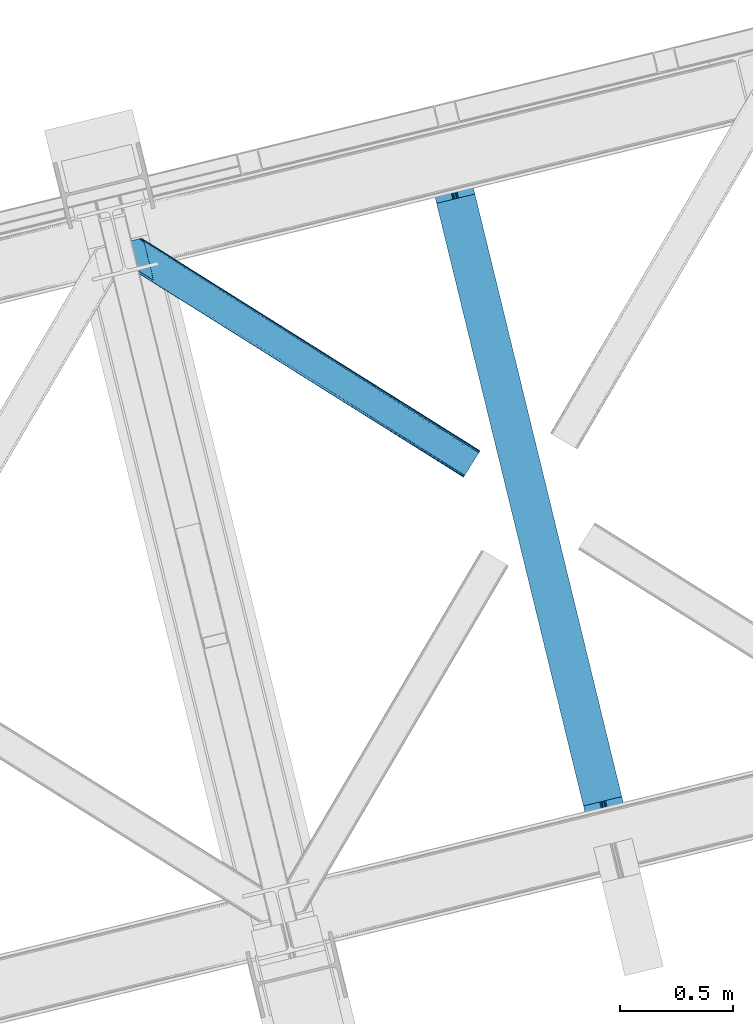
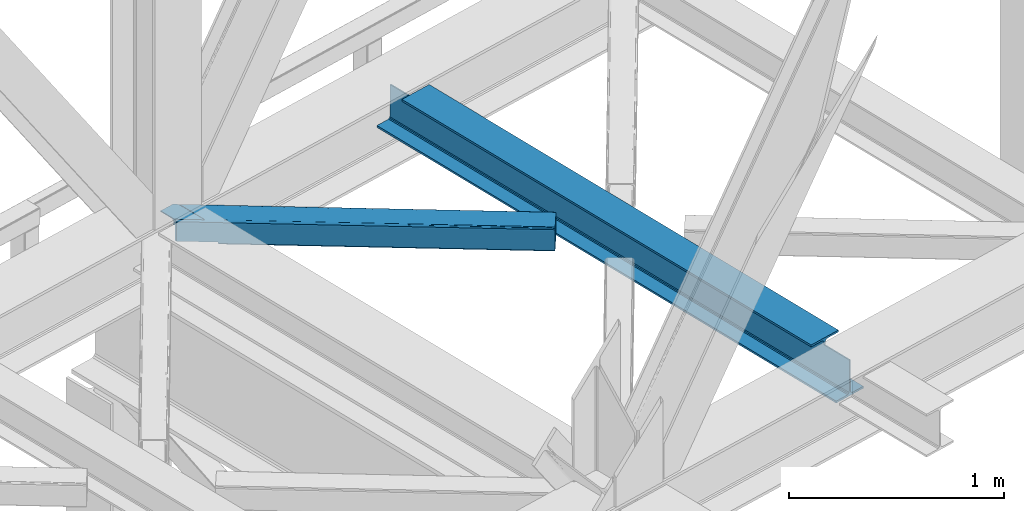
# One storey, part 32 of 92: 1 beam, 1 member.
"""IFC4 building model written with IfcOpenShell, lengths in millimetres."""

from ifc_helpers import new_model, entity, si_unit, converted_unit, derived_unit, direction, frame, origin, place, context, subcontext, project, spatial, triangles, polygons, material, type_object, element, save


model = new_model("IFC4")

# Units and contexts
model_context = context("Model", 3, precision=0.01, world=origin(), true_north=direction((6.12303176911189e-17, 1.0)))
plan_context = context("Plan", 3, precision=0.01, world=origin(), true_north=direction((6.12303176911189e-17, 1.0)))
body_context = subcontext(model_context, "Body", "Model", "MODEL_VIEW")
ifc_project = project(units=[si_unit("LENGTHUNIT", "METRE", prefix="MILLI"), si_unit("AREAUNIT", "SQUARE_METRE"), si_unit("VOLUMEUNIT", "CUBIC_METRE"), converted_unit("PLANEANGLEUNIT", "DEGREE", entity("IfcRatioMeasure", 0.0174532925199433), si_unit("PLANEANGLEUNIT", "RADIAN"), dimensions=[0, 0, 0, 0, 0, 0, 0]), si_unit("MASSUNIT", "GRAM", prefix="KILO"), derived_unit("MASSDENSITYUNIT", [(si_unit("MASSUNIT", "GRAM", prefix="KILO"), 1), (si_unit("LENGTHUNIT", "METRE"), -3)]), derived_unit("MOMENTOFINERTIAUNIT", [(si_unit("LENGTHUNIT", "METRE"), 4)]), si_unit("TIMEUNIT", "SECOND"), si_unit("FREQUENCYUNIT", "HERTZ"), si_unit("THERMODYNAMICTEMPERATUREUNIT", "DEGREE_CELSIUS"), derived_unit("THERMALTRANSMITTANCEUNIT", [(si_unit("MASSUNIT", "GRAM", prefix="KILO"), 1), (si_unit("THERMODYNAMICTEMPERATUREUNIT", "KELVIN"), -1), (si_unit("TIMEUNIT", "SECOND"), -3)]), derived_unit("VOLUMETRICFLOWRATEUNIT", [(si_unit("LENGTHUNIT", "METRE"), 3), (si_unit("TIMEUNIT", "SECOND"), -1)]), derived_unit("MASSFLOWRATEUNIT", [(si_unit("MASSUNIT", "GRAM", prefix="KILO"), 1), (si_unit("TIMEUNIT", "SECOND"), -1)]), derived_unit("ROTATIONALFREQUENCYUNIT", [(si_unit("TIMEUNIT", "SECOND"), -1)]), si_unit("ELECTRICCURRENTUNIT", "AMPERE"), si_unit("ELECTRICVOLTAGEUNIT", "VOLT"), si_unit("POWERUNIT", "WATT"), si_unit("FORCEUNIT", "NEWTON", prefix="KILO"), si_unit("ILLUMINANCEUNIT", "LUX"), si_unit("LUMINOUSFLUXUNIT", "LUMEN"), si_unit("LUMINOUSINTENSITYUNIT", "CANDELA"), derived_unit("USERDEFINED", [(si_unit("MASSUNIT", "GRAM", prefix="KILO"), -1), (si_unit("LENGTHUNIT", "METRE"), -2), (si_unit("TIMEUNIT", "SECOND"), 3), (si_unit("LUMINOUSFLUXUNIT", "LUMEN"), 1)]), derived_unit("LINEARVELOCITYUNIT", [(si_unit("LENGTHUNIT", "METRE"), 1), (si_unit("TIMEUNIT", "SECOND"), -1)]), si_unit("PRESSUREUNIT", "PASCAL"), derived_unit("USERDEFINED", [(si_unit("LENGTHUNIT", "METRE"), -2), (si_unit("MASSUNIT", "GRAM", prefix="KILO"), 1), (si_unit("TIMEUNIT", "SECOND"), -2)]), derived_unit("LINEARFORCEUNIT", [(si_unit("MASSUNIT", "GRAM", prefix="KILO"), 1), (si_unit("LENGTHUNIT", "METRE"), 1), (si_unit("TIMEUNIT", "SECOND"), -2), (si_unit("LENGTHUNIT", "METRE"), -1)]), derived_unit("PLANARFORCEUNIT", [(si_unit("MASSUNIT", "GRAM", prefix="KILO"), 1), (si_unit("LENGTHUNIT", "METRE"), 1), (si_unit("TIMEUNIT", "SECOND"), -2), (si_unit("LENGTHUNIT", "METRE"), -2)])], contexts=[model_context, plan_context])

# Site, building, storey
site_placement = place(None, origin())
site = spatial("IfcSite", under=ifc_project, at=site_placement, CompositionType="ELEMENT")
building_placement = place(site_placement, origin())
building = spatial("IfcBuilding", under=site, at=building_placement, CompositionType="ELEMENT")
storey_placement = place(building_placement, frame((0.0, 0.0, 15900.0)))
storey = spatial("IfcBuildingStorey", under=building, at=storey_placement, Name="05", CompositionType="ELEMENT", Elevation=15900.0)

# Beam
ifc_material = material(Name="Metal painted (White)")
beam_type = type_object("IfcBeamType", PredefinedType="BEAM")
beam_placement = place(storey_placement, frame((-53806.58, 4670.78, 3441.0)))
element("IfcBeam", 1, at=beam_placement, inside=storey, type_object=beam_type, material=ifc_material, ObjectType="Steel Beam", PredefinedType="BEAM", context=body_context, shape_type="Tessellation", body=[
    polygons([(900.985346189432, 41.4445662733081, 11.000000000004), (900.985346189432, 41.4445662733081, 2.16573425859679e-12), (170.021610174752, 3040.13999372697, 2.16573425859679e-12), (170.021610174752, 3040.13999372697, 11.000000000004), (834.919806235814, 25.3403919499656, 11.000000000004), (103.956070221144, 3024.03581940362, 11.000000000004), (828.971056214531, 23.8903211957396, 12.2179274798217), (98.0073201998513, 3022.5857486494, 12.2179274798217), (823.927949458422, 22.66101056892, 15.6862915010192), (92.9642134437427, 3021.35643802258, 15.6862915010192), (820.558253255246, 21.8396114687119, 20.8770650821657), (89.5945172405668, 3020.53503892237, 20.8770650821657), (819.374973305552, 21.5511744621206, 27.0000000000047), (88.4112372908809, 3020.24660191578, 27.0000000000047), (81.6103728838888, 3018.58881926485, 27.0000000000047), (81.6103728838888, 3018.58881926485, 203.000000000006), (88.4112372908723, 3020.24660191578, 203.000000000006), (-8.66293703438714e-12, 2998.69542745366, 2.16573425859679e-12), (8.66293703438714e-12, 2998.69542745366, 10.9999999999997), (66.0655399536259, 3014.799601777, 11.000000000004), (72.0142899749184, 3016.24967253123, 12.2179274798217), (77.0573967310357, 3017.47898315805, 15.6862915010192), (80.4270929342029, 3018.30038225826, 20.8770650821657), (819.374973305552, 21.5511744621206, 203.000000000006), (812.574108898559, 19.8933918111881, 203.000000000006), (812.574108898559, 19.8933918111881, 27.0000000000047), (811.390828948873, 19.6049548045968, 20.8770650821657), (808.021132745698, 18.7835557043887, 15.6862915010192), (802.978025989598, 17.5542450775691, 12.2179274798217), (797.029275968305, 16.1041743233431, 11.000000000004), (730.963736014671, 0.0, 10.9999999999997), (730.963736014671, 0.0, 2.16573425859679e-12), (779.675212882749, 184.415062601692, 203.069791966819), (128.020401343504, 2857.75452019162, 203.000000000006), (128.243282132658, 2856.8401777572, 203.617301946336), (128.256196377177, 2856.7871977843, 217.000003693143), (779.530009633833, 185.010597404072, 217.000003676718), (779.530880241722, 185.007025963192, 204.00000679514), (772.96491171832, 182.385463974442, 203.006342981529), (772.742064056782, 183.299815969774, 203.617301946336), (772.729149812254, 183.352795942667, 217.000003693143), (121.455336555608, 2855.1293963229, 217.000003676718), (121.454465947718, 2855.13296776377, 204.00000679514), (121.310166358664, 2855.72494066435, 203.076120467494), (121.219536936511, 2856.09673754069, 203.000000000006), (780.71349435786, 185.298194377514, 223.122939328039), (784.082490766547, 186.122464201395, 228.313710402595), (789.125126170563, 187.353708426699, 231.782072735464), (795.073705041266, 188.804481281381, 232.999999602236), (861.139155906781, 204.909021065315, 232.999999283132), (861.137682570352, 204.915065042188, 243.999994005812), (691.11630166644, 163.469558245298, 243.999994827032), (691.117775002877, 163.463514268424, 233.000000104353), (757.183225868401, 179.568054052359, 232.999999785253), (763.132130996722, 181.017488520583, 231.782072861016), (768.175695503862, 182.244921343718, 228.313710479427), (771.546082413593, 183.063487001147, 223.12293937232), (120.271851831572, 2854.84179934945, 223.122939328039), (116.902855422901, 2854.01752952557, 228.313710402595), (111.860220018877, 2852.78628530027, 231.782072735464), (105.911641148174, 2851.33551244559, 232.999999602236), (39.8461902826505, 2835.23097266165, 232.999999283128), (39.8476636190881, 2835.22492868478, 243.999994005812), (209.869044523001, 2876.67043548167, 243.999994827032), (209.867571186563, 2876.67647945854, 233.000000104357), (143.80212032104, 2860.57193967461, 232.999999785253), (137.853215192718, 2859.12250520639, 231.782072861012), (132.809650685587, 2857.89507238325, 228.313710479427), (129.439263775847, 2857.07650672582, 223.12293937232)], [[[1, 2, 3, 4]], [[5, 1, 4, 6]], [[7, 5, 6, 8]], [[9, 7, 8, 10]], [[11, 9, 10, 12]], [[13, 11, 12, 14]], [[15, 16, 17, 14, 12, 10, 8, 6, 4, 3, 18, 19, 20, 21, 22, 23]], [[13, 24, 25, 26, 27, 28, 29, 30, 31, 32, 2, 1, 5, 7, 9, 11]], [[2, 32, 18, 3]], [[32, 31, 19, 18]], [[31, 30, 20, 19]], [[27, 26, 15, 23]], [[28, 27, 23, 22]], [[29, 28, 22, 21]], [[30, 29, 21, 20]], [[33, 24, 13, 14, 17, 34, 35, 36, 37, 38]], [[25, 39, 40, 41, 42, 43, 44, 16, 15, 26]], [[39, 25, 24, 33]], [[45, 34, 17, 16]], [[41, 40, 38, 37, 46, 47, 48, 49, 50, 51, 52, 53, 54, 55, 56, 57]], [[42, 58, 59, 60, 61, 62, 63, 64, 65, 66, 67, 68, 69, 36, 35, 43]], [[46, 37, 36, 69]], [[47, 46, 69, 68]], [[48, 47, 68, 67]], [[49, 48, 67, 66]], [[50, 49, 66, 65]], [[51, 50, 65, 64]], [[52, 51, 64, 63]], [[53, 52, 63, 62]], [[54, 53, 62, 61]], [[55, 54, 61, 60]], [[56, 55, 60, 59]], [[57, 56, 59, 58]], [[41, 57, 58, 42]]], closed=False),
])

# Member
member_type = type_object("IfcMemberType", PredefinedType="BRACE")
member_placement = place(storey_placement, frame((-55162.19, 6291.05, 3511.0)))
element("IfcMember", 2, at=member_placement, inside=storey, type_object=member_type, ObjectType="Steel Horizontal Brace", PredefinedType="BRACE", context=body_context, shape_type="Tessellation", body=[
    triangles([(207.722204589845, 841.064360046386, 0.0), (172.045312499999, 987.426937866211, 0.0), (1579.92216796875, 103.755294799805, 0.0), (1524.10231933594, 14.8217697143555, 0.0), (1589.22392578125, 118.577645874023, 17.5000946044929), (1588.5169921875, 117.449226379395, 10.8028289794929), (166.547973632813, 1009.96393432617, 10.8028289794929), (166.096838378908, 1011.82079772949, 17.5000946044929), (1586.49851074219, 114.236050415039, 5.12526855468968), (167.840917968751, 1004.67646636963, 5.12526855468968), (1583.48474121094, 109.42762298584, 1.33247680664135), (169.766381835936, 996.762414550781, 1.33247680664135), (1520.53974609375, 9.15002288818323, 1.33247680664135), (202.587634277341, 836.378599548339, 1.33247680664135), (208.512854003908, 837.822697448731, 0.155804443362285), (1517.5259765625, 4.34101409912091, 5.12526855468968), (194.895080566406, 834.503713989257, 5.12526855468968), (1515.50749511718, 1.12783813476563, 10.8028289794929), (189.755859375, 833.250883483886, 10.8028289794929), (1514.80056152344, 0.0, 17.5000946044929), (187.951318359374, 832.810794067383, 17.5000946044929), (204.382873535156, 836.815782165527, 12.1260040283232), (208.512854003908, 837.822697448731, 9.69243164062573), (199.652929687501, 835.662945556641, 17.9802978515654), (198.425097656247, 835.364126586914, 19.4999725341804), (187.951318359374, 832.810794067383, 19.4999725341804), (25.310083007811, 934.894679260254, 19.4999725341804), (22.6823364257798, 945.669602966308, 19.4999725341804), (1514.80056152344, 0.0, 122.500662231447), (25.310083007811, 934.894679260254, 122.500662231447), (1527.82302246094, 20.7510589599606, 6.99957275390625), (205.340954589839, 850.821903991699, 6.99957275390625), (207.559423828126, 841.724203491211, 8.88434143066479), (1524.26510009765, 15.0787307739256, 8.3320495605476), (1521.2466796875, 10.2697219848633, 12.1260040283232), (1519.22819824218, 7.05654602050799, 17.8035644531265), (1518.52126464844, 5.92870788574237, 24.4996673583992), (22.9334838867144, 944.652223205566, 24.4996673583992), (174.421911621095, 977.669393920898, 6.99957275390625), (1576.20146484375, 97.8260055541987, 6.99957275390625), (168.971081542964, 1000.03372650147, 17.8803039550803), (170.217517089841, 994.918341064453, 12.1260040283232), (172.147631835935, 987.004870605469, 8.3320495605476), (168.836206054686, 1000.58485565185, 18.5000335693367), (166.096838378908, 1011.82079772949, 18.5000335693367), (1518.52126464844, 5.92870788574237, 115.501089477541), (22.9334838867144, 944.652223205566, 115.501089477541), (1527.82302246094, 20.7510589599606, 133.000021362306), (1524.26510009765, 15.0787307739256, 131.667544555665), (19.2592895507769, 959.71118774414, 131.667544555665), (16.9850097656235, 969.046083068847, 133.000021362306), (1521.2466796875, 10.2697219848633, 127.87475280762), (21.1894042968706, 951.797135925292, 127.87475280762), (1519.22819824218, 7.05654602050799, 122.196029663086), (22.4776977539077, 946.509086608887, 122.196029663086), (168.515295410158, 1000.87902374268, 18.7407165527366), (165.808483886714, 1012.00101928711, 18.736065673831), (168.171130371091, 1001.19702758789, 19.0000030517585), (165.492224121095, 1012.2021697998, 19.0000030517585), (167.826965332031, 1001.5150314331, 19.2592895507842), (165.17131347656, 1012.4033203125, 19.2639404296897), (167.510705566405, 1001.80919952393, 19.4999725341804), (164.882958984374, 1012.58354187012, 19.4999725341804), (78.2975463867188, 1057.80461883545, 19.4999725341804), (88.7666748046831, 1060.35795135498, 19.4999725341804), (24.8589477539063, 936.751542663574, 129.197927856447), (23.5706542968765, 942.040173339844, 134.874325561526), (22.1242309570298, 947.964811706543, 137.999716186525), (0.0, 1038.71973724365, 137.999716186525), (0.0, 1038.71973724365, 133.000021362306), (1589.22392578125, 118.577645874023, 122.500662231447), (88.7666748046831, 1060.35795135498, 122.500662231447), (1584.7962890625, 111.520518493652, 17.8035644531265), (1585.50322265625, 112.648356628418, 24.4996673583992), (79.2835327148423, 1058.04588317871, 24.4996673583992), (1579.75938720703, 103.498333740235, 8.3320495605476), (1582.77780761719, 108.307342529297, 12.1260040283232), (64.647216796875, 1054.47807769775, 131.667544555665), (55.5733520507783, 1052.26600341797, 133.000021362306), (76.0651245117188, 1057.26104736328, 137.999716186525), (81.8229125976577, 1058.66503143311, 134.874325561526), (72.3397705078096, 1056.35296325684, 127.87475280762), (77.4789916992158, 1057.60579376221, 122.196029663086), (86.962133789064, 1059.91786193848, 129.197927856447), (79.2835327148423, 1058.04588317871, 115.501089477541), (1576.20146484375, 97.8260055541987, 133.000021362306), (1585.50322265625, 112.648356628418, 115.501089477541), (1584.7962890625, 111.520518493652, 122.196029663086), (1582.77780761719, 108.307342529297, 127.87475280762), (1579.75938720703, 103.498333740235, 131.667544555665), (1588.5169921875, 117.449226379395, 129.197927856447), (1586.49851074219, 114.236050415039, 134.874325561526), (1583.48474121094, 109.42762298584, 138.667117309571), (1579.92216796875, 103.755294799805, 139.999594116212), (1524.10231933594, 14.8217697143555, 139.999594116212), (1520.53974609375, 9.15002288818323, 138.667117309571), (1517.5259765625, 4.34101409912091, 134.874325561526), (1515.50749511718, 1.12783813476563, 129.197927856447), (98.1940063476577, 1043.37177886963, 137.999716186525), (139.391491699214, 874.36000213623, 137.999716186525), (137.847399902341, 884.922148132324, 139.999594116212), (139.828674316406, 876.794155883789, 138.999655151369), (140.051916503908, 875.629692077637, 138.667117309571), (139.805419921875, 874.273379516601, 138.076455688479), (139.921691894531, 874.907643127442, 138.353182983399), (98.7102539062471, 1042.87471618652, 138.076455688479), (99.6032226562456, 1040.78589019775, 138.634561157229), (99.1985961914033, 1041.72304229736, 138.383413696291), (100.189233398436, 1039.41271820068, 138.999655151369), (102.170507812501, 1031.28472595215, 139.999594116212), (140.037963867188, 875.543650817871, 138.629910278323)], [[1, 2, 3], [3, 4, 1], [5, 6, 7], [7, 8, 5], [6, 9, 10], [10, 7, 6], [9, 11, 12], [12, 10, 9], [11, 3, 2], [2, 12, 11], [13, 14, 15], [15, 4, 13], [15, 1, 4], [13, 16, 14], [17, 14, 16], [16, 18, 17], [19, 17, 18], [18, 20, 19], [21, 19, 20], [22, 23, 14], [22, 14, 17], [17, 19, 24], [23, 15, 14], [24, 22, 17], [19, 21, 25], [26, 25, 21], [19, 25, 24], [27, 28, 25], [25, 26, 27], [26, 29, 30], [20, 26, 21], [26, 20, 29], [26, 30, 27], [31, 32, 33], [34, 33, 23], [23, 35, 34], [23, 22, 35], [36, 35, 22], [37, 36, 24], [24, 25, 37], [37, 25, 38], [28, 38, 25], [22, 24, 36], [33, 34, 31], [39, 32, 40], [31, 40, 32], [41, 7, 10], [10, 42, 41], [12, 42, 10], [42, 12, 43], [7, 44, 8], [45, 8, 44], [7, 41, 44], [43, 12, 2], [33, 32, 1], [1, 39, 2], [39, 1, 32], [15, 33, 1], [39, 43, 2], [23, 33, 15], [46, 37, 38], [38, 47, 46], [48, 49, 50], [50, 51, 48], [49, 52, 53], [53, 50, 49], [52, 54, 55], [55, 53, 52], [54, 46, 47], [47, 55, 54], [45, 44, 56], [56, 57, 45], [57, 56, 58], [58, 59, 57], [59, 58, 60], [60, 61, 59], [61, 60, 62], [62, 63, 61], [64, 65, 63], [63, 62, 64], [47, 27, 30], [66, 55, 30], [55, 66, 67], [55, 47, 30], [38, 27, 47], [28, 27, 38], [53, 55, 67], [68, 51, 50], [51, 68, 69], [69, 70, 51], [50, 53, 68], [68, 53, 67], [5, 45, 71], [8, 45, 5], [45, 72, 71], [72, 45, 57], [72, 57, 59], [59, 61, 72], [63, 72, 61], [72, 63, 65], [73, 41, 42], [74, 75, 62], [62, 73, 74], [56, 73, 58], [56, 44, 73], [73, 60, 58], [73, 62, 60], [44, 41, 73], [75, 64, 62], [40, 76, 39], [43, 39, 76], [76, 77, 43], [42, 43, 77], [42, 77, 73], [78, 79, 80], [81, 82, 80], [78, 80, 82], [83, 81, 84], [79, 69, 80], [79, 70, 69], [83, 82, 81], [72, 85, 83], [85, 72, 65], [75, 65, 64], [65, 75, 85], [72, 83, 84], [51, 79, 86], [79, 51, 70], [86, 48, 51], [74, 87, 75], [85, 75, 87], [87, 88, 85], [83, 85, 88], [88, 89, 83], [82, 83, 89], [89, 90, 82], [78, 82, 90], [90, 86, 78], [79, 78, 86], [91, 89, 88], [87, 5, 71], [91, 88, 71], [91, 92, 89], [88, 87, 71], [89, 92, 93], [86, 94, 95], [94, 90, 93], [90, 94, 86], [90, 89, 93], [6, 77, 9], [74, 5, 87], [5, 73, 6], [73, 5, 74], [6, 73, 77], [3, 40, 4], [11, 9, 77], [77, 76, 11], [76, 40, 3], [3, 11, 76], [52, 96, 97], [95, 48, 86], [95, 49, 48], [49, 95, 96], [52, 49, 96], [46, 29, 20], [98, 54, 52], [97, 98, 52], [54, 98, 29], [46, 54, 29], [13, 35, 16], [4, 40, 31], [31, 34, 4], [34, 35, 13], [13, 4, 34], [18, 16, 35], [20, 37, 46], [36, 20, 18], [20, 36, 37], [36, 18, 35], [80, 68, 99], [80, 69, 68], [100, 99, 68], [95, 101, 102], [102, 96, 95], [102, 103, 96], [97, 104, 100], [100, 67, 97], [100, 68, 67], [96, 105, 104], [96, 103, 105], [104, 97, 96], [29, 98, 30], [66, 30, 98], [98, 97, 66], [67, 66, 97], [92, 81, 106], [106, 93, 92], [107, 93, 108], [106, 108, 93], [81, 80, 99], [107, 94, 93], [107, 109, 94], [109, 110, 94], [92, 91, 84], [84, 81, 92], [91, 71, 72], [72, 84, 91], [110, 101, 94], [95, 94, 101], [111, 102, 109], [109, 107, 111], [107, 108, 104], [108, 106, 104], [110, 109, 101], [102, 101, 109]]),
])

save(model, "model.ifc")
